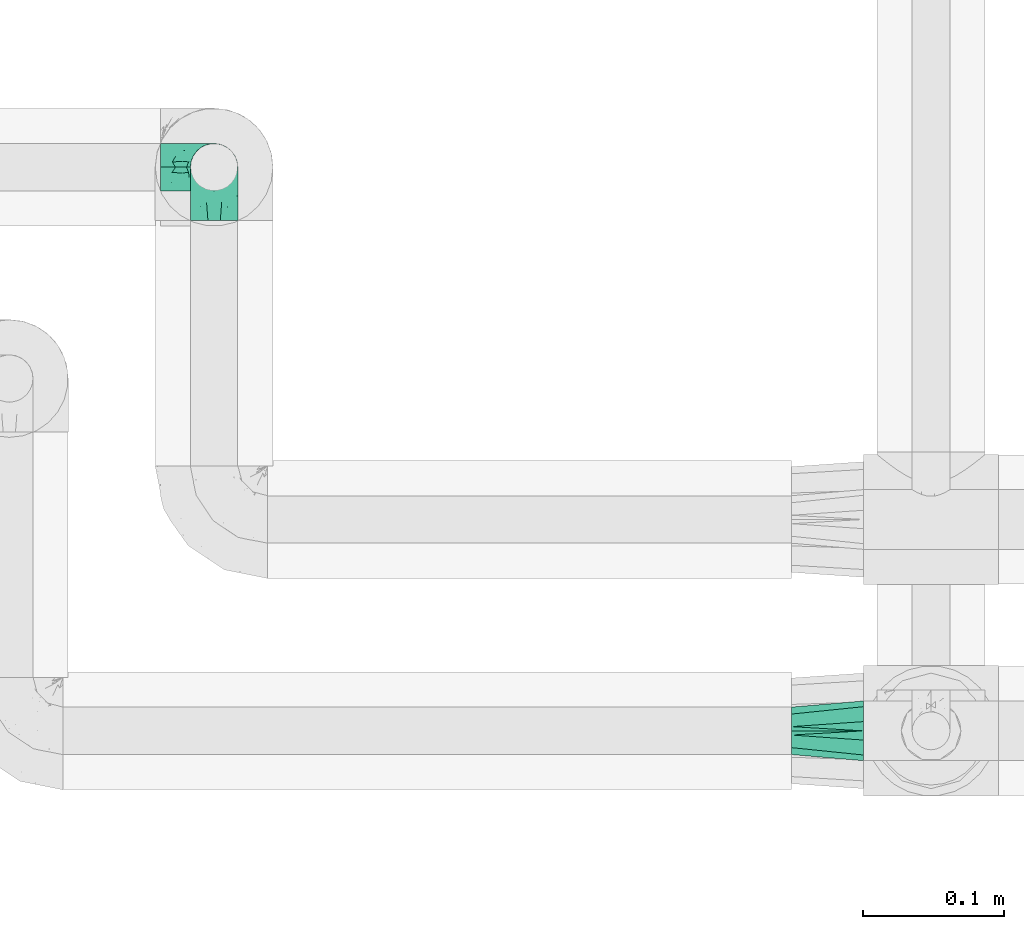
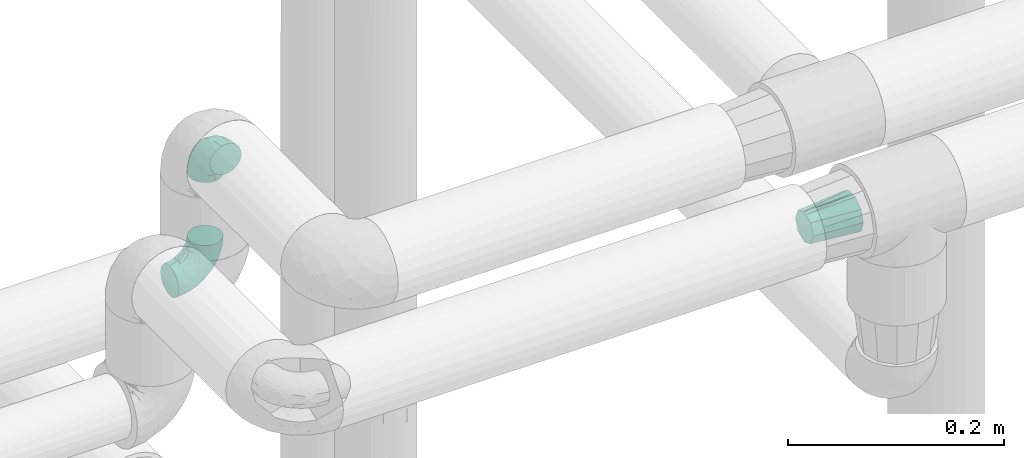
# One storey, part 809 of 827: 3 flow fittings.
"""IFC2X3 building model written with IfcOpenShell, lengths in millimetres."""

from ifc_helpers import new_model, entity, si_unit, converted_unit, derived_unit, direction, frame, origin, place, context, subcontext, project, spatial, faceted_brep, source, transform, mapped, material, type_object, type_shapes, element, save


model = new_model("IFC2X3")

# Units and contexts
model_context = context("Model", 3, precision=0.01, world=origin(), true_north=direction((6.12303176911189e-17, 1.0)))
body_context = subcontext(model_context, "Body", "Model", "MODEL_VIEW")
ifc_project = project(units=[si_unit("LENGTHUNIT", "METRE", prefix="MILLI"), si_unit("AREAUNIT", "SQUARE_METRE"), si_unit("VOLUMEUNIT", "CUBIC_METRE"), converted_unit("PLANEANGLEUNIT", "DEGREE", entity("IfcRatioMeasure", 0.0174532925199433), si_unit("PLANEANGLEUNIT", "RADIAN"), dimensions=[0, 0, 0, 0, 0, 0, 0]), si_unit("MASSUNIT", "GRAM", prefix="KILO"), derived_unit("MASSDENSITYUNIT", [(si_unit("MASSUNIT", "GRAM", prefix="KILO"), 1), (si_unit("LENGTHUNIT", "METRE"), -3)]), derived_unit("MOMENTOFINERTIAUNIT", [(si_unit("LENGTHUNIT", "METRE"), 4)]), si_unit("TIMEUNIT", "SECOND"), si_unit("FREQUENCYUNIT", "HERTZ"), si_unit("THERMODYNAMICTEMPERATUREUNIT", "DEGREE_CELSIUS"), derived_unit("THERMALTRANSMITTANCEUNIT", [(si_unit("MASSUNIT", "GRAM", prefix="KILO"), 1), (si_unit("THERMODYNAMICTEMPERATUREUNIT", "KELVIN"), -1), (si_unit("TIMEUNIT", "SECOND"), -3)]), derived_unit("VOLUMETRICFLOWRATEUNIT", [(si_unit("LENGTHUNIT", "METRE"), 3), (si_unit("TIMEUNIT", "SECOND"), -1)]), derived_unit("MASSFLOWRATEUNIT", [(si_unit("MASSUNIT", "GRAM", prefix="KILO"), 1), (si_unit("TIMEUNIT", "SECOND"), -1)]), derived_unit("ROTATIONALFREQUENCYUNIT", [(si_unit("TIMEUNIT", "SECOND"), -1)]), si_unit("ELECTRICCURRENTUNIT", "AMPERE"), si_unit("ELECTRICVOLTAGEUNIT", "VOLT"), si_unit("POWERUNIT", "WATT"), si_unit("FORCEUNIT", "NEWTON", prefix="KILO"), si_unit("ILLUMINANCEUNIT", "LUX"), si_unit("LUMINOUSFLUXUNIT", "LUMEN"), si_unit("LUMINOUSINTENSITYUNIT", "CANDELA"), derived_unit("USERDEFINED", [(si_unit("MASSUNIT", "GRAM", prefix="KILO"), -1), (si_unit("LENGTHUNIT", "METRE"), -2), (si_unit("TIMEUNIT", "SECOND"), 3), (si_unit("LUMINOUSFLUXUNIT", "LUMEN"), 1)]), derived_unit("LINEARVELOCITYUNIT", [(si_unit("LENGTHUNIT", "METRE"), 1), (si_unit("TIMEUNIT", "SECOND"), -1)]), si_unit("PRESSUREUNIT", "PASCAL"), derived_unit("USERDEFINED", [(si_unit("LENGTHUNIT", "METRE"), -2), (si_unit("MASSUNIT", "GRAM", prefix="KILO"), 1), (si_unit("TIMEUNIT", "SECOND"), -2)]), derived_unit("LINEARFORCEUNIT", [(si_unit("MASSUNIT", "GRAM", prefix="KILO"), 1), (si_unit("LENGTHUNIT", "METRE"), 1), (si_unit("TIMEUNIT", "SECOND"), -2), (si_unit("LENGTHUNIT", "METRE"), -1)]), derived_unit("PLANARFORCEUNIT", [(si_unit("MASSUNIT", "GRAM", prefix="KILO"), 1), (si_unit("LENGTHUNIT", "METRE"), 1), (si_unit("TIMEUNIT", "SECOND"), -2), (si_unit("LENGTHUNIT", "METRE"), -2)])], contexts=[model_context])

# Site, building, storey
site_placement = place(None, origin())
site = spatial("IfcSite", under=ifc_project, at=site_placement, CompositionType="ELEMENT")
building_placement = place(site_placement, origin())
building = spatial("IfcBuilding", under=site, at=building_placement, CompositionType="ELEMENT")
storey_placement = place(building_placement, frame((0.0, 0.0, 28200.0)))
storey = spatial("IfcBuildingStorey", under=building, at=storey_placement, Name="08", CompositionType="ELEMENT", Elevation=28200.0)

# Flow fittings
ifc_material = material()
pipe_fitting_type_1 = type_object("IfcPipeFittingType", Name="ADSK_1", PredefinedType="NOTDEFINED", material=ifc_material)
shared_shape_1 = source(origin(), body_context, "Body", "Brep", [
    faceted_brep([(51.0, 0.0, 16.85), (51.0, -2.98, 15.62), (51.0, -5.96, 14.38), (51.0, -8.94, 13.15), (51.0, -11.91, 11.91), (51.0, -13.15, 8.94), (51.0, -14.38, 5.96), (51.0, -15.62, 2.98), (51.0, -16.85, 0.0), (51.0, -15.62, -2.98), (51.0, -14.38, -5.96), (51.0, -13.15, -8.94), (51.0, -11.91, -11.91), (51.0, -8.94, -13.15), (51.0, -5.96, -14.38), (51.0, -2.98, -15.62), (51.0, 0.0, -16.85), (51.0, 2.98, -15.62), (51.0, 5.96, -14.38), (51.0, 8.94, -13.15), (51.0, 11.91, -11.91), (51.0, 13.15, -8.94), (51.0, 14.38, -5.96), (51.0, 15.62, -2.98), (51.0, 16.85, 0.0), (51.0, 15.62, 2.98), (51.0, 14.38, 5.96), (51.0, 13.15, 8.94), (51.0, 11.91, 11.91), (51.0, 8.94, 13.15), (51.0, 5.96, 14.38), (51.0, 2.98, 15.62), (0.0, -6.55, 20.16), (0.0, 0.0, 20.16), (0.0, 6.55, 20.16), (0.0, 11.85, 16.31), (0.0, 17.15, 12.46), (0.0, 19.18, 6.23), (0.0, 21.2, 0.0), (0.0, 19.18, -6.23), (0.0, 18.16, -9.35), (0.0, 17.15, -12.46), (0.0, 11.85, -16.31), (0.0, 6.55, -20.16), (0.0, 0.0, -20.16), (0.0, -6.55, -20.16), (0.0, -11.85, -16.31), (0.0, -17.15, -12.46), (0.0, -19.18, -6.23), (0.0, -21.2, 0.0), (0.0, -19.18, 6.23), (0.0, -18.16, 9.35), (0.0, -17.15, 12.46), (0.0, -11.85, 16.31)], [[[0, 1, 2, 3, 4, 5, 6, 7, 8, 9, 10, 11, 12, 13, 14, 15, 16, 17, 18, 19, 20, 21, 22, 23, 24, 25, 26, 27, 28, 29, 30, 31]], [[32, 33, 34, 35, 36, 37, 38, 39, 40, 41, 42, 43, 44, 45, 46, 47, 48, 49, 50, 51, 52, 53]], [[21, 20, 41]], [[11, 10, 47, 12]], [[40, 39, 22]], [[14, 13, 12, 46]], [[48, 9, 49]], [[46, 45, 14]], [[16, 15, 44]], [[42, 41, 20]], [[12, 47, 46]], [[16, 44, 17]], [[24, 23, 38]], [[43, 17, 44]], [[44, 15, 45]], [[19, 18, 42, 20]], [[39, 38, 23]], [[48, 47, 10]], [[15, 14, 45]], [[43, 18, 17]], [[8, 49, 9]], [[39, 23, 22]], [[40, 21, 41]], [[40, 22, 21]], [[43, 42, 18]], [[48, 10, 9]], [[5, 4, 52]], [[27, 26, 36, 28]], [[51, 50, 6]], [[30, 29, 28, 35]], [[37, 25, 38]], [[35, 34, 30]], [[0, 31, 33]], [[53, 52, 4]], [[28, 36, 35]], [[0, 33, 1]], [[8, 7, 49]], [[32, 1, 33]], [[33, 31, 34]], [[3, 2, 53, 4]], [[50, 49, 7]], [[37, 36, 26]], [[31, 30, 34]], [[32, 2, 1]], [[24, 38, 25]], [[50, 7, 6]], [[51, 5, 52]], [[51, 6, 5]], [[32, 53, 2]], [[37, 26, 25]]]),
])
type_shapes(pipe_fitting_type_1, [shared_shape_1])
flow_fitting_1_placement = place(storey_placement, frame((19728.27, 9342.8, 2996.46), z_axis=(0.0, 0.0, 1.0), x_axis=(-1.0, 0.0, 0.0)))
element("IfcFlowFitting", 1, at=flow_fitting_1_placement, inside=storey, type_object=pipe_fitting_type_1, material=ifc_material, Name="ADSK_1", ObjectType="ADSK_1", context=body_context, shape_type="MappedRepresentation", body=[
    mapped(shared_shape_1, transform((0.0, 0.0, 0.0), scale=1.0)),
])
pipe_fitting_type_2 = type_object("IfcPipeFittingType", Name="ADSK_1", PredefinedType="NOTDEFINED", material=ifc_material)
shared_shape_2 = source(origin(), body_context, "Body", "Brep", [
    faceted_brep([(-38.0, 0.0, -16.85), (-38.0, -4.36, -16.28), (-38.0, -8.43, -14.59), (-38.0, -11.91, -11.91), (-38.0, -14.59, -8.43), (-38.0, -16.28, -4.36), (-38.0, -16.85, 0.0), (-38.0, -16.28, 4.36), (-38.0, -14.59, 8.42), (-38.0, -11.91, 11.91), (-38.0, -8.43, 14.59), (-38.0, -4.36, 16.28), (-38.0, 0.0, 16.85), (-38.0, 4.36, 16.28), (-38.0, 8.42, 14.59), (-38.0, 11.91, 11.91), (-38.0, 14.59, 8.42), (-38.0, 16.28, 4.36), (-38.0, 16.85, 0.0), (-38.0, 16.28, -4.36), (-38.0, 14.59, -8.43), (-38.0, 11.91, -11.91), (-38.0, 8.42, -14.59), (-38.0, 4.36, -16.28), (0.0, 38.0, -16.85), (-4.36, 38.0, -16.28), (-8.43, 38.0, -14.59), (-11.92, 38.0, -11.91), (-14.59, 38.0, -8.43), (-16.28, 38.0, -4.36), (-16.85, 38.0, 0.0), (-16.28, 38.0, 4.36), (-14.59, 38.0, 8.42), (-11.92, 38.0, 11.91), (-8.43, 38.0, 14.59), (-4.36, 38.0, 16.28), (0.0, 38.0, 16.85), (4.36, 38.0, 16.28), (8.42, 38.0, 14.59), (11.91, 38.0, 11.91), (14.59, 38.0, 8.42), (16.28, 38.0, 4.36), (16.85, 38.0, 0.0), (16.28, 38.0, -4.36), (14.59, 38.0, -8.43), (11.91, 38.0, -11.91), (8.42, 38.0, -14.59), (4.36, 38.0, -16.28), (-27.91, -12.9, 9.54), (-27.51, -14.76, 0.0), (-16.53, -9.86, 8.66), (-24.93, -9.38, 12.63), (-29.29, -2.05, 16.58), (-26.82, 2.86, 16.81), (-25.18, -14.43, 5.37), (-4.54, 4.54, 14.04), (-15.36, -3.29, 14.19), (-7.56, -2.74, 10.89), (-28.06, -6.15, 15.21), (9.38, 24.93, 12.63), (-4.71, -4.42, 5.51), (-14.62, -10.99, 4.34), (-8.11, -6.73, 0.0), (-19.46, 0.42, 16.39), (-29.53, 14.25, 10.97), (-26.45, 18.14, 7.62), (-32.84, 15.94, 6.96), (-23.4, 16.22, 12.05), (-11.89, 8.53, 16.79), (-5.59, 13.42, 16.64), (-6.64, 18.62, 16.81), (-32.37, 10.35, 13.72), (-6.4, 32.67, 15.76), (-2.55, 28.48, 16.8), (6.81, 15.56, 11.71), (3.29, 15.36, 14.19), (-29.89, 18.0, 3.79), (-29.34, 6.81, 15.88), (-10.27, 4.27, 15.87), (-2.97, 11.0, 15.66), (2.45, 6.84, 10.65), (-1.8, -0.14, 8.44), (5.0, 5.5, 5.57), (-17.68, 27.4, 7.52), (14.43, 25.18, 5.37), (12.9, 27.91, 9.54), (9.86, 16.53, 8.66), (6.15, 28.06, 15.21), (-17.01, -12.67, 0.0), (2.05, 29.29, 16.58), (14.76, 27.51, 0.0), (10.99, 14.62, 4.34), (12.67, 17.01, 0.0), (-15.84, -6.82, 11.83), (-7.71, 25.61, 16.01), (-22.69, 22.69, 4.1), (-19.68, 27.43, 0.0), (-27.43, 19.68, 0.0), (-18.11, 29.67, 3.72), (-10.87, 29.33, 13.9), (-20.83, 21.64, 8.95), (-18.54, 20.86, 11.76), (-14.08, 30.19, 10.92), (-13.69, 20.27, 14.88), (-20.85, 7.92, 16.51), (-19.04, 4.79, 16.85), (-19.82, 12.26, 15.55), (-19.27, 16.43, 13.96), (-10.72, 19.56, 16.07), (-13.94, 13.94, 16.38), (-0.42, 19.46, 16.39), (-25.32, 12.08, 14.15), (-9.04, -6.0, 8.28), (0.78, -0.78, 0.0), (6.73, 8.11, 0.0), (-9.04, -6.0, -8.28), (-15.9, -7.04, -11.65), (-7.56, -2.74, -10.89), (6.15, 28.06, -15.21), (3.29, 15.36, -14.19), (-0.42, 19.46, -16.39), (-30.19, 14.08, -10.92), (-29.33, 10.87, -13.9), (-25.61, 7.71, -16.01), (-32.67, 6.4, -15.76), (-29.67, 18.11, -3.72), (-18.14, 26.45, -7.62), (-22.69, 22.69, -4.1), (-18.0, 29.89, -3.79), (-25.18, -14.43, -5.37), (-14.62, -10.99, -4.34), (-20.27, 13.69, -14.88), (-15.36, -3.29, -14.19), (-14.25, 29.52, -10.97), (-15.94, 32.84, -6.96), (-24.93, -9.38, -12.63), (-27.91, -12.9, -9.54), (6.81, 15.56, -11.71), (9.38, 24.93, -12.63), (-7.92, 20.85, -16.51), (-4.79, 19.04, -16.85), (-8.53, 11.89, -16.79), (-29.29, -2.05, -16.58), (-13.42, 5.59, -16.64), (-4.27, 10.26, -15.87), (-11.0, 2.97, -15.66), (-16.53, -9.86, -8.66), (-28.48, 2.55, -16.8), (-18.62, 6.64, -16.81), (10.99, 14.62, -4.34), (14.43, 25.18, -5.37), (-12.26, 19.82, -15.55), (-16.43, 19.27, -13.96), (12.9, 27.91, -9.54), (-10.35, 32.37, -13.72), (-6.81, 29.34, -15.88), (2.05, 29.29, -16.58), (-2.86, 26.82, -16.81), (-27.4, 17.68, -7.52), (5.0, 5.5, -5.57), (-16.22, 23.4, -12.05), (-28.06, -6.15, -15.21), (9.86, 16.53, -8.66), (-20.86, 18.54, -11.76), (-21.64, 20.83, -8.95), (-19.56, 10.72, -16.07), (-19.46, 0.42, -16.39), (-12.08, 25.32, -14.15), (-4.54, 4.54, -14.04), (-13.94, 13.94, -16.38), (2.45, 6.84, -10.65), (-4.71, -4.42, -5.51), (-1.8, -0.14, -8.44)], [[[0, 1, 2, 3, 4, 5, 6, 7, 8, 9, 10, 11, 12, 13, 14, 15, 16, 17, 18, 19, 20, 21, 22, 23]], [[24, 25, 26, 27, 28, 29, 30, 31, 32, 33, 34, 35, 36, 37, 38, 39, 40, 41, 42, 43, 44, 45, 46, 47]], [[8, 48, 9]], [[7, 6, 49]], [[48, 50, 51]], [[12, 52, 53]], [[8, 54, 48]], [[7, 54, 8]], [[55, 56, 57]], [[51, 10, 9]], [[51, 58, 10]], [[59, 39, 38]], [[60, 61, 62]], [[58, 56, 63]], [[64, 65, 66]], [[67, 65, 64]], [[68, 69, 70]], [[14, 71, 15]], [[11, 52, 12]], [[35, 72, 73]], [[12, 53, 13]], [[15, 64, 16]], [[74, 59, 75]], [[18, 17, 76]], [[66, 17, 16]], [[77, 13, 53]], [[13, 77, 14]], [[69, 78, 79]], [[80, 81, 82]], [[32, 31, 83]], [[84, 85, 86]], [[59, 87, 75]], [[61, 54, 88]], [[36, 89, 37]], [[84, 41, 40]], [[36, 35, 73]], [[90, 41, 84]], [[40, 39, 85]], [[10, 58, 11]], [[85, 84, 40]], [[91, 84, 86]], [[84, 92, 90]], [[87, 38, 37]], [[93, 56, 51]], [[94, 70, 73]], [[95, 96, 97]], [[84, 91, 92]], [[96, 98, 30]], [[34, 33, 99]], [[76, 95, 97]], [[100, 101, 83]], [[102, 99, 33]], [[65, 95, 76]], [[103, 94, 99]], [[95, 98, 96]], [[72, 99, 94]], [[72, 35, 34]], [[101, 99, 102]], [[7, 49, 54]], [[87, 59, 38]], [[104, 105, 68]], [[106, 103, 107]], [[106, 77, 104]], [[33, 32, 102]], [[108, 103, 109]], [[94, 108, 70]], [[89, 73, 110]], [[71, 64, 15]], [[111, 107, 67]], [[50, 48, 54]], [[51, 9, 48]], [[56, 58, 51]], [[88, 54, 49]], [[52, 58, 63]], [[50, 112, 93]], [[56, 55, 78]], [[39, 59, 85]], [[86, 85, 59]], [[89, 87, 37]], [[42, 41, 90]], [[110, 79, 75]], [[110, 75, 87]], [[75, 55, 80]], [[104, 77, 53]], [[71, 77, 111]], [[32, 83, 102]], [[101, 102, 83]], [[99, 101, 103]], [[106, 107, 111]], [[68, 70, 109]], [[110, 73, 70]], [[68, 109, 104]], [[68, 63, 78]], [[57, 93, 112]], [[80, 55, 57]], [[61, 50, 54]], [[80, 82, 86]], [[81, 57, 112]], [[74, 86, 59]], [[60, 113, 82]], [[82, 114, 91]], [[100, 95, 65]], [[98, 95, 83]], [[73, 89, 36]], [[87, 89, 110]], [[58, 52, 11]], [[53, 52, 63]], [[104, 53, 105]], [[106, 104, 109]], [[18, 76, 97]], [[76, 17, 66]], [[103, 106, 109]], [[77, 106, 111]], [[103, 101, 107]], [[67, 107, 101]], [[67, 101, 100]], [[111, 67, 64]], [[83, 31, 98]], [[30, 98, 31]], [[53, 63, 105]], [[63, 68, 105]], [[56, 78, 63]], [[79, 78, 55]], [[75, 79, 55]], [[69, 79, 110]], [[70, 69, 110]], [[78, 69, 68]], [[62, 113, 60]], [[112, 61, 60]], [[61, 88, 62]], [[86, 82, 91]], [[77, 71, 14]], [[114, 82, 113]], [[114, 92, 91]], [[64, 71, 111]], [[99, 72, 34]], [[73, 72, 94]], [[64, 66, 16]], [[76, 66, 65]], [[95, 100, 83]], [[67, 100, 65]], [[75, 80, 74]], [[80, 86, 74]], [[70, 108, 109]], [[94, 103, 108]], [[50, 93, 51]], [[57, 56, 93]], [[61, 112, 50]], [[81, 112, 60]], [[82, 81, 60]], [[80, 57, 81]], [[115, 116, 117]], [[118, 119, 120]], [[121, 122, 21]], [[123, 124, 122]], [[97, 125, 18]], [[126, 127, 128]], [[127, 97, 96]], [[129, 130, 88]], [[123, 122, 131]], [[116, 132, 117]], [[133, 126, 134]], [[22, 124, 23]], [[3, 135, 136]], [[137, 119, 138]], [[129, 88, 49]], [[139, 140, 141]], [[4, 3, 136]], [[46, 118, 47]], [[142, 1, 0]], [[143, 144, 145]], [[4, 129, 5]], [[129, 136, 146]], [[147, 0, 23]], [[22, 21, 122]], [[127, 125, 97]], [[123, 148, 147]], [[96, 128, 127]], [[149, 150, 92]], [[30, 29, 128]], [[151, 131, 152]], [[27, 133, 28]], [[153, 45, 44]], [[135, 3, 2]], [[27, 26, 154]], [[155, 26, 25]], [[24, 156, 157]], [[24, 47, 156]], [[20, 19, 158]], [[159, 149, 114]], [[126, 133, 160]], [[141, 143, 148]], [[46, 138, 118]], [[161, 135, 2]], [[155, 25, 157]], [[23, 124, 147]], [[115, 146, 116]], [[45, 153, 138]], [[138, 46, 45]], [[153, 162, 138]], [[161, 2, 1]], [[42, 90, 43]], [[130, 129, 146]], [[49, 5, 129]], [[43, 150, 44]], [[163, 122, 121]], [[24, 157, 25]], [[135, 161, 132]], [[134, 29, 28]], [[43, 90, 150]], [[164, 163, 158]], [[151, 155, 139]], [[21, 20, 121]], [[123, 131, 165]], [[123, 165, 148]], [[142, 147, 166]], [[154, 133, 27]], [[167, 152, 160]], [[146, 136, 135]], [[6, 5, 49]], [[129, 4, 136]], [[142, 161, 1]], [[166, 145, 132]], [[166, 132, 161]], [[132, 168, 117]], [[44, 150, 153]], [[92, 150, 90]], [[162, 153, 150]], [[119, 118, 138]], [[156, 118, 120]], [[137, 138, 162]], [[119, 168, 144]], [[139, 155, 157]], [[154, 155, 167]], [[20, 158, 121]], [[163, 121, 158]], [[122, 163, 131]], [[151, 152, 167]], [[141, 148, 169]], [[166, 147, 148]], [[141, 169, 139]], [[141, 120, 144]], [[168, 170, 117]], [[159, 171, 172]], [[115, 172, 171]], [[171, 62, 130]], [[119, 170, 168]], [[170, 162, 159]], [[149, 162, 150]], [[113, 171, 159]], [[164, 127, 126]], [[125, 127, 158]], [[147, 142, 0]], [[161, 142, 166]], [[118, 156, 47]], [[157, 156, 120]], [[139, 157, 140]], [[151, 139, 169]], [[30, 128, 96]], [[128, 29, 134]], [[131, 151, 169]], [[155, 151, 167]], [[131, 163, 152]], [[160, 152, 163]], [[160, 163, 164]], [[167, 160, 133]], [[158, 19, 125]], [[18, 125, 19]], [[157, 120, 140]], [[120, 141, 140]], [[119, 144, 120]], [[145, 144, 168]], [[132, 145, 168]], [[143, 145, 166]], [[148, 143, 166]], [[144, 143, 141]], [[115, 130, 146]], [[114, 113, 159]], [[62, 171, 113]], [[62, 88, 130]], [[159, 162, 149]], [[149, 92, 114]], [[155, 154, 26]], [[133, 154, 167]], [[122, 124, 22]], [[147, 124, 123]], [[133, 134, 28]], [[128, 134, 126]], [[127, 164, 158]], [[160, 164, 126]], [[162, 170, 137]], [[170, 119, 137]], [[131, 169, 165]], [[148, 165, 169]], [[146, 135, 116]], [[132, 116, 135]], [[172, 115, 117]], [[130, 115, 171]], [[117, 170, 172]], [[159, 172, 170]]]),
])
type_shapes(pipe_fitting_type_2, [shared_shape_2])
flow_fitting_2_placement = place(storey_placement, frame((19267.48, 9742.8, 2850.01), z_axis=(0.0, -1.0, 0.0), x_axis=(1.0, 0.0, -1.92641960334142e-05)))
element("IfcFlowFitting", 2, at=flow_fitting_2_placement, inside=storey, type_object=pipe_fitting_type_2, material=ifc_material, Name="ADSK_1", ObjectType="ADSK_1", context=body_context, shape_type="MappedRepresentation", body=[
    mapped(shared_shape_2, transform((0.0, 0.0, 0.0), scale=1.0)),
])
pipe_fitting_type_3 = type_object("IfcPipeFittingType", Name="ADSK_1", PredefinedType="NOTDEFINED", material=ifc_material)
shared_shape_3 = source(origin(), body_context, "Body", "Brep", [
    faceted_brep([(-38.0, 0.0, -16.85), (-38.0, -4.36, -16.28), (-38.0, -8.43, -14.59), (-38.0, -11.91, -11.91), (-38.0, -14.59, -8.43), (-38.0, -16.28, -4.36), (-38.0, -16.85, 0.0), (-38.0, -16.28, 4.36), (-38.0, -14.59, 8.42), (-38.0, -11.91, 11.91), (-38.0, -8.43, 14.59), (-38.0, -4.36, 16.28), (-38.0, 0.0, 16.85), (-38.0, 4.36, 16.28), (-38.0, 8.42, 14.59), (-38.0, 11.91, 11.91), (-38.0, 14.59, 8.42), (-38.0, 16.28, 4.36), (-38.0, 16.85, 0.0), (-38.0, 16.28, -4.36), (-38.0, 14.59, -8.43), (-38.0, 11.91, -11.91), (-38.0, 8.42, -14.59), (-38.0, 4.36, -16.28), (-4.36, 38.0, -16.28), (-8.42, 38.0, -14.59), (-11.91, 38.0, -11.91), (-14.59, 38.0, -8.43), (-16.27, 38.0, -4.36), (-16.85, 38.0, 0.0), (-16.27, 38.0, 4.36), (-14.59, 38.0, 8.42), (-11.91, 38.0, 11.91), (-8.42, 38.0, 14.59), (-4.36, 38.0, 16.28), (0.0, 38.0, 16.85), (4.36, 38.0, 16.28), (8.43, 38.0, 14.59), (11.92, 38.0, 11.91), (14.59, 38.0, 8.42), (16.28, 38.0, 4.36), (16.85, 38.0, 0.0), (16.28, 38.0, -4.36), (14.59, 38.0, -8.43), (11.92, 38.0, -11.91), (8.43, 38.0, -14.59), (4.36, 38.0, -16.28), (0.0, 38.0, -16.85), (-27.9, -12.9, 9.54), (-27.5, -14.76, 0.0), (-16.53, -9.86, 8.66), (-24.93, -9.38, 12.63), (-29.29, -2.05, 16.58), (-26.82, 2.86, 16.81), (-25.18, -14.43, 5.37), (-4.54, 4.54, 14.04), (-15.35, -3.29, 14.19), (-7.56, -2.74, 10.9), (-28.05, -6.15, 15.21), (9.38, 24.93, 12.63), (-4.71, -4.42, 5.51), (-14.61, -10.99, 4.34), (-8.11, -6.73, 0.0), (-19.46, 0.42, 16.39), (-29.52, 14.25, 10.97), (-26.45, 18.14, 7.62), (-32.84, 15.94, 6.96), (-23.39, 16.22, 12.05), (-11.89, 8.53, 16.79), (-5.59, 13.42, 16.64), (-6.64, 18.62, 16.81), (-32.36, 10.35, 13.72), (-6.4, 32.67, 15.76), (-2.55, 28.47, 16.8), (6.81, 15.55, 11.71), (3.29, 15.35, 14.19), (-29.89, 18.0, 3.79), (-29.34, 6.81, 15.88), (-10.26, 4.27, 15.87), (-2.96, 11.0, 15.66), (2.45, 6.84, 10.65), (-1.8, -0.14, 8.44), (5.0, 5.49, 5.57), (-17.68, 27.4, 7.52), (14.43, 25.18, 5.37), (12.9, 27.9, 9.54), (9.86, 16.53, 8.66), (6.15, 28.05, 15.21), (-17.01, -12.68, 0.0), (2.06, 29.29, 16.58), (14.76, 27.5, 0.0), (10.99, 14.61, 4.34), (12.68, 17.01, 0.0), (-15.84, -6.82, 11.84), (-7.7, 25.61, 16.01), (-22.68, 22.69, 4.1), (-19.68, 27.42, 0.0), (-27.42, 19.68, 0.0), (-18.11, 29.67, 3.72), (-10.87, 29.33, 13.9), (-20.82, 21.64, 8.95), (-18.54, 20.86, 11.76), (-14.08, 30.18, 10.92), (-13.68, 20.27, 14.88), (-20.85, 7.92, 16.51), (-19.04, 4.79, 16.85), (-19.82, 12.26, 15.55), (-19.26, 16.43, 13.96), (-10.72, 19.56, 16.07), (-13.94, 13.94, 16.38), (-0.41, 19.46, 16.39), (-25.32, 12.08, 14.15), (-9.03, -6.0, 8.28), (0.79, -0.79, 0.0), (6.73, 8.11, 0.0), (-9.03, -6.0, -8.28), (-15.89, -7.04, -11.65), (-7.56, -2.74, -10.9), (6.15, 28.05, -15.21), (3.29, 15.35, -14.19), (-0.41, 19.46, -16.39), (-30.18, 14.08, -10.92), (-29.33, 10.87, -13.9), (-25.61, 7.71, -16.01), (-32.67, 6.4, -15.76), (-29.67, 18.11, -3.72), (-18.14, 26.45, -7.62), (-22.68, 22.69, -4.1), (-18.0, 29.89, -3.79), (-25.18, -14.43, -5.37), (-14.61, -10.99, -4.34), (-20.27, 13.69, -14.88), (-15.35, -3.29, -14.19), (-14.25, 29.52, -10.97), (-15.94, 32.84, -6.96), (-24.93, -9.38, -12.63), (-27.9, -12.9, -9.54), (6.81, 15.55, -11.71), (9.38, 24.93, -12.63), (-7.92, 20.85, -16.51), (-4.79, 19.04, -16.85), (-8.53, 11.89, -16.79), (-29.29, -2.05, -16.58), (-13.42, 5.59, -16.64), (-4.27, 10.26, -15.87), (-11.0, 2.97, -15.66), (-16.53, -9.86, -8.66), (-28.47, 2.55, -16.8), (-18.62, 6.64, -16.81), (10.99, 14.61, -4.34), (14.43, 25.18, -5.37), (-12.26, 19.82, -15.55), (-16.43, 19.27, -13.96), (12.9, 27.9, -9.54), (-10.35, 32.36, -13.72), (-6.81, 29.34, -15.88), (2.06, 29.29, -16.58), (-2.86, 26.82, -16.81), (-27.4, 17.68, -7.52), (5.0, 5.49, -5.57), (-16.22, 23.39, -12.05), (-28.05, -6.15, -15.21), (9.86, 16.53, -8.66), (-20.86, 18.54, -11.76), (-21.64, 20.82, -8.95), (-19.56, 10.72, -16.07), (-13.94, 13.94, -16.38), (-19.46, 0.42, -16.39), (-12.08, 25.32, -14.15), (-4.54, 4.54, -14.04), (2.45, 6.84, -10.65), (-4.71, -4.42, -5.51), (-1.8, -0.14, -8.44)], [[[0, 1, 2, 3, 4, 5, 6, 7, 8, 9, 10, 11, 12, 13, 14, 15, 16, 17, 18, 19, 20, 21, 22, 23]], [[24, 25, 26, 27, 28, 29, 30, 31, 32, 33, 34, 35, 36, 37, 38, 39, 40, 41, 42, 43, 44, 45, 46, 47]], [[8, 48, 9]], [[7, 6, 49]], [[48, 50, 51]], [[12, 52, 53]], [[8, 54, 48]], [[7, 54, 8]], [[55, 56, 57]], [[51, 10, 9]], [[51, 58, 10]], [[59, 38, 37]], [[60, 61, 62]], [[58, 56, 63]], [[64, 65, 66]], [[67, 65, 64]], [[68, 69, 70]], [[14, 71, 15]], [[11, 52, 12]], [[34, 72, 73]], [[12, 53, 13]], [[15, 64, 16]], [[74, 59, 75]], [[18, 17, 76]], [[66, 17, 16]], [[77, 13, 53]], [[13, 77, 14]], [[69, 78, 79]], [[80, 81, 82]], [[31, 30, 83]], [[84, 85, 86]], [[59, 87, 75]], [[61, 54, 88]], [[35, 89, 36]], [[84, 40, 39]], [[35, 34, 73]], [[90, 40, 84]], [[39, 38, 85]], [[10, 58, 11]], [[85, 84, 39]], [[91, 84, 86]], [[84, 92, 90]], [[87, 37, 36]], [[93, 56, 51]], [[94, 70, 73]], [[95, 96, 97]], [[84, 91, 92]], [[96, 98, 29]], [[33, 32, 99]], [[76, 95, 97]], [[100, 101, 83]], [[102, 99, 32]], [[65, 95, 76]], [[103, 94, 99]], [[95, 98, 96]], [[72, 99, 94]], [[72, 34, 33]], [[101, 99, 102]], [[7, 49, 54]], [[87, 59, 37]], [[104, 105, 68]], [[106, 103, 107]], [[106, 77, 104]], [[32, 31, 102]], [[108, 103, 109]], [[94, 108, 70]], [[89, 73, 110]], [[71, 64, 15]], [[111, 107, 67]], [[50, 48, 54]], [[51, 9, 48]], [[56, 58, 51]], [[88, 54, 49]], [[52, 58, 63]], [[50, 112, 93]], [[56, 55, 78]], [[38, 59, 85]], [[86, 85, 59]], [[89, 87, 36]], [[41, 40, 90]], [[110, 79, 75]], [[110, 75, 87]], [[75, 55, 80]], [[104, 77, 53]], [[71, 77, 111]], [[31, 83, 102]], [[101, 102, 83]], [[99, 101, 103]], [[106, 107, 111]], [[68, 70, 109]], [[110, 73, 70]], [[68, 109, 104]], [[68, 63, 78]], [[57, 93, 112]], [[80, 55, 57]], [[61, 50, 54]], [[80, 82, 86]], [[81, 57, 112]], [[74, 86, 59]], [[60, 113, 82]], [[82, 114, 91]], [[100, 95, 65]], [[98, 95, 83]], [[73, 89, 35]], [[87, 89, 110]], [[58, 52, 11]], [[53, 52, 63]], [[104, 53, 105]], [[106, 104, 109]], [[18, 76, 97]], [[76, 17, 66]], [[103, 106, 109]], [[77, 106, 111]], [[103, 101, 107]], [[67, 107, 101]], [[67, 101, 100]], [[111, 67, 64]], [[83, 30, 98]], [[29, 98, 30]], [[53, 63, 105]], [[63, 68, 105]], [[56, 78, 63]], [[79, 78, 55]], [[75, 79, 55]], [[69, 79, 110]], [[70, 69, 110]], [[78, 69, 68]], [[62, 113, 60]], [[112, 61, 60]], [[61, 88, 62]], [[86, 82, 91]], [[77, 71, 14]], [[114, 82, 113]], [[114, 92, 91]], [[64, 71, 111]], [[99, 72, 33]], [[73, 72, 94]], [[64, 66, 16]], [[76, 66, 65]], [[95, 100, 83]], [[67, 100, 65]], [[75, 80, 74]], [[80, 86, 74]], [[70, 108, 109]], [[94, 103, 108]], [[50, 93, 51]], [[57, 56, 93]], [[61, 112, 50]], [[81, 112, 60]], [[82, 81, 60]], [[80, 57, 81]], [[115, 116, 117]], [[118, 119, 120]], [[121, 122, 21]], [[123, 124, 122]], [[97, 125, 18]], [[126, 127, 128]], [[127, 97, 96]], [[129, 130, 88]], [[123, 122, 131]], [[116, 132, 117]], [[133, 126, 134]], [[22, 124, 23]], [[3, 135, 136]], [[137, 119, 138]], [[129, 88, 49]], [[139, 140, 141]], [[4, 3, 136]], [[45, 118, 46]], [[142, 1, 0]], [[143, 144, 145]], [[4, 129, 5]], [[129, 136, 146]], [[147, 0, 23]], [[22, 21, 122]], [[127, 125, 97]], [[123, 148, 147]], [[96, 128, 127]], [[149, 150, 92]], [[29, 28, 128]], [[151, 131, 152]], [[26, 133, 27]], [[153, 44, 43]], [[135, 3, 2]], [[26, 25, 154]], [[155, 25, 24]], [[47, 156, 157]], [[47, 46, 156]], [[20, 19, 158]], [[159, 149, 114]], [[126, 133, 160]], [[141, 143, 148]], [[45, 138, 118]], [[161, 135, 2]], [[155, 24, 157]], [[23, 124, 147]], [[115, 146, 116]], [[44, 153, 138]], [[138, 45, 44]], [[153, 162, 138]], [[161, 2, 1]], [[41, 90, 42]], [[130, 129, 146]], [[49, 5, 129]], [[42, 150, 43]], [[163, 122, 121]], [[47, 157, 24]], [[135, 161, 132]], [[134, 28, 27]], [[42, 90, 150]], [[164, 163, 158]], [[151, 155, 139]], [[21, 20, 121]], [[165, 131, 166]], [[123, 165, 148]], [[142, 147, 167]], [[154, 133, 26]], [[168, 152, 160]], [[146, 136, 135]], [[6, 5, 49]], [[129, 4, 136]], [[142, 161, 1]], [[167, 145, 132]], [[167, 132, 161]], [[132, 169, 117]], [[43, 150, 153]], [[92, 150, 90]], [[162, 153, 150]], [[119, 118, 138]], [[156, 118, 120]], [[137, 138, 162]], [[119, 169, 144]], [[139, 155, 157]], [[154, 155, 168]], [[20, 158, 121]], [[163, 121, 158]], [[122, 163, 131]], [[151, 152, 168]], [[141, 148, 166]], [[167, 147, 148]], [[141, 166, 139]], [[141, 120, 144]], [[169, 170, 117]], [[159, 171, 172]], [[115, 172, 171]], [[171, 62, 130]], [[119, 170, 169]], [[170, 162, 159]], [[149, 162, 150]], [[113, 171, 159]], [[164, 127, 126]], [[125, 127, 158]], [[147, 142, 0]], [[161, 142, 167]], [[118, 156, 46]], [[157, 156, 120]], [[139, 157, 140]], [[151, 139, 166]], [[29, 128, 96]], [[128, 28, 134]], [[131, 151, 166]], [[155, 151, 168]], [[131, 163, 152]], [[160, 152, 163]], [[160, 163, 164]], [[168, 160, 133]], [[158, 19, 125]], [[18, 125, 19]], [[157, 120, 140]], [[120, 141, 140]], [[119, 144, 120]], [[145, 144, 169]], [[132, 145, 169]], [[143, 145, 167]], [[148, 143, 167]], [[144, 143, 141]], [[115, 130, 146]], [[114, 113, 159]], [[62, 171, 113]], [[62, 88, 130]], [[159, 162, 149]], [[149, 92, 114]], [[155, 154, 25]], [[133, 154, 168]], [[122, 124, 22]], [[147, 124, 123]], [[133, 134, 27]], [[128, 134, 126]], [[127, 164, 158]], [[160, 164, 126]], [[162, 170, 137]], [[170, 119, 137]], [[148, 165, 166]], [[123, 131, 165]], [[146, 135, 116]], [[132, 116, 135]], [[172, 115, 117]], [[130, 115, 171]], [[117, 170, 172]], [[159, 172, 170]]]),
])
type_shapes(pipe_fitting_type_3, [shared_shape_3])
flow_fitting_3_placement = place(storey_placement, frame((19267.48, 9742.8, 2997.22), z_axis=(1.0, 0.0, 0.0), x_axis=(0.0, 0.0, 1.0)))
element("IfcFlowFitting", 3, at=flow_fitting_3_placement, inside=storey, type_object=pipe_fitting_type_3, material=ifc_material, Name="ADSK_1", ObjectType="ADSK_1", context=body_context, shape_type="MappedRepresentation", body=[
    mapped(shared_shape_3, transform((0.0, 0.0, 0.0), scale=1.0)),
])

save(model, "model.ifc")
